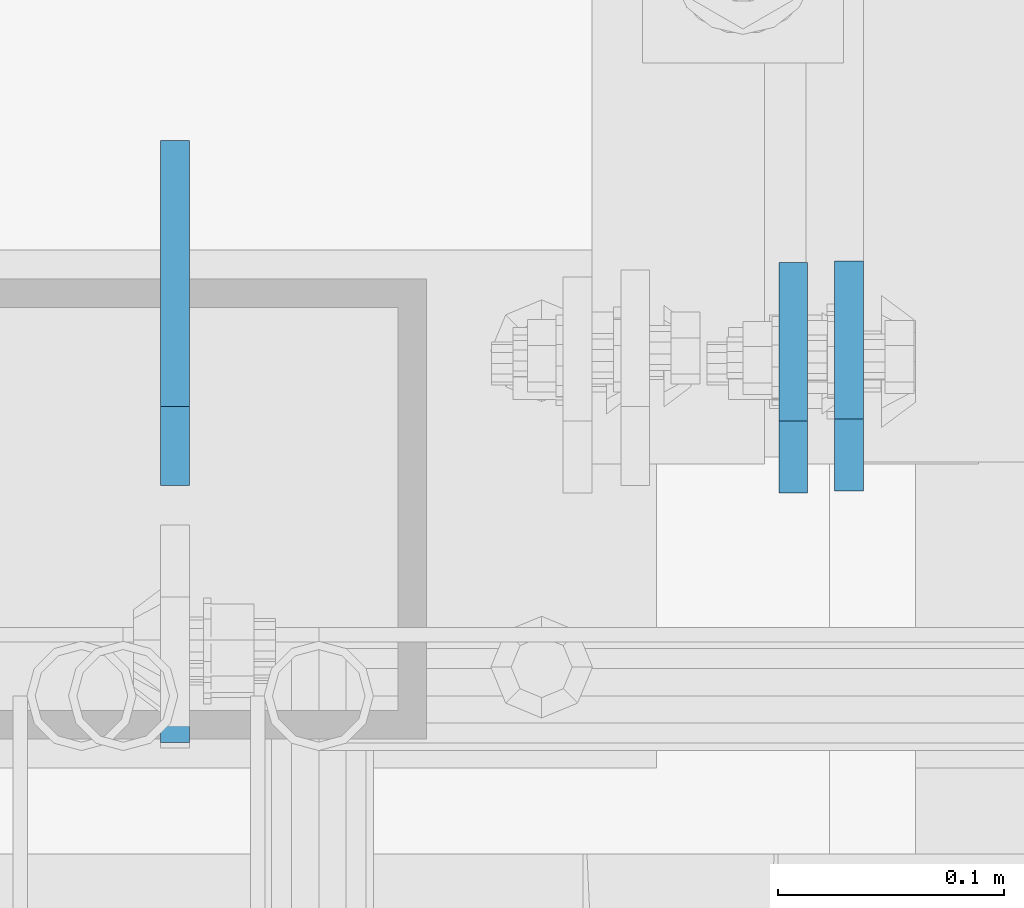
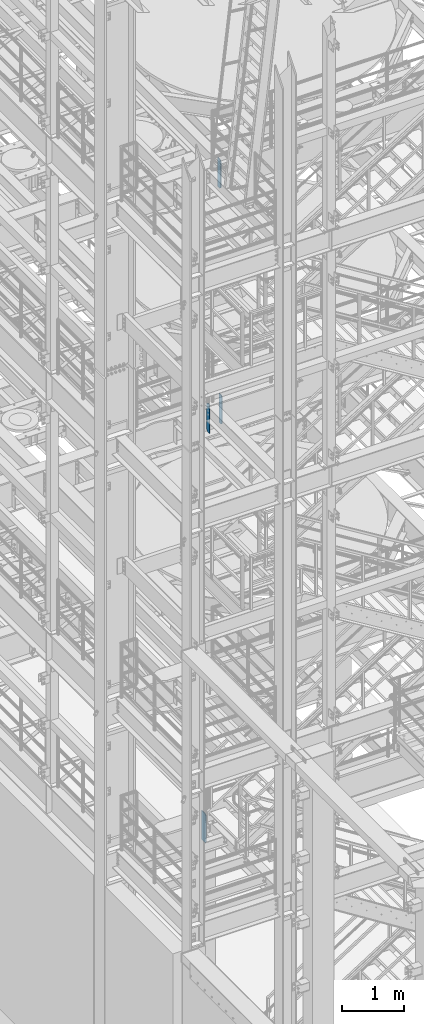
# One storey, part 1470 of 1876: 4 plates, 3 elements without a shape of their own.
"""IFC2X3 building model written with IfcOpenShell, lengths in millimetres."""

from ifc_helpers import new_model, si_unit, frame, origin_with_axes, place, context, subcontext, project, spatial, faceted_brep, material, type_object, element, aggregate, save


model = new_model("IFC2X3")

# Units and contexts
model_context = context("Model", 3, precision=1e-05, world=origin_with_axes())
body_context = subcontext(model_context, "Body", "Model", "MODEL_VIEW")
ifc_project = project(units=[si_unit("LENGTHUNIT", "METRE", prefix="MILLI"), si_unit("AREAUNIT", "SQUARE_METRE"), si_unit("VOLUMEUNIT", "CUBIC_METRE"), si_unit("MASSUNIT", "GRAM", prefix="KILO"), si_unit("TIMEUNIT", "SECOND"), si_unit("PLANEANGLEUNIT", "RADIAN"), si_unit("SOLIDANGLEUNIT", "STERADIAN"), si_unit("THERMODYNAMICTEMPERATUREUNIT", "DEGREE_CELSIUS"), si_unit("LUMINOUSINTENSITYUNIT", "LUMEN")], contexts=[model_context])

# Site, building, storey
site_placement = place(None, origin_with_axes())
site = spatial("IfcSite", under=ifc_project, at=site_placement, CompositionType="ELEMENT")
building_placement = place(site_placement, origin_with_axes())
building = spatial("IfcBuilding", under=site, at=building_placement, Name="Undefined", CompositionType="ELEMENT")
storey_placement = place(building_placement, origin_with_axes())
storey = spatial("IfcBuildingStorey", under=building, at=storey_placement, Name="Undefined", CompositionType="ELEMENT", Elevation=0.0)

# Assembly, plates
assembly_1_placement = place(storey_placement, origin_with_axes())
assembly_1 = element("IfcElementAssembly", 1, at=assembly_1_placement, inside=storey, Name="BEAM", AssemblyPlace="NOTDEFINED", PredefinedType="RIGID_FRAME")
ifc_material = material(Name="STEEL/A36")
plate_type_1 = type_object("IfcPlateType", PredefinedType="NOTDEFINED")
plate_1_placement = place(assembly_1_placement, frame((1717.67499990463, -4579.9375, 12709.525), z_axis=(0.0, 0.0, 1.0), x_axis=(0.0, -1.0, 0.0)))
plate_1 = element("IfcPlate", 2, at=plate_1_placement, type_object=plate_type_1, material=ifc_material, Name="PLATE", context=body_context, shape_type="Brep", body=[
    faceted_brep([(0.0, -6.34999999999991, 34.9249992370605), (0.0, -6.35000000000036, 538.162475585938), (0.0, 6.35000000000036, 538.162475585938), (0.0, 6.34999999999991, 34.9249992370605), (34.9249992370605, -6.34999999999991, 573.087524414062), (34.9249992370605, 6.34999999999991, 573.087524414062), (95.25, -6.34999999999991, 573.087524414062), (95.25, 6.34999999999991, 573.087524414062), (95.25, -6.35000000000036, 0.0), (95.25, 6.35000000000036, 0.0), (34.9249992370605, -6.34999999999991, 0.0), (34.9249992370605, 6.34999999999991, 0.0)], [[[0, 1, 2, 3]], [[1, 4, 5, 2]], [[4, 6, 7, 5]], [[6, 8, 9, 7]], [[8, 10, 11, 9]], [[10, 0, 3, 11]], [[5, 7, 9, 11, 3, 2]], [[10, 8, 6, 4, 1, 0]]]),
])
plate_type_2 = type_object("IfcPlateType", PredefinedType="NOTDEFINED")
plate_2_placement = place(assembly_1_placement, frame((2015.33153078443, -4564.0625, 12709.525), z_axis=(0.0, 0.0, 1.0), x_axis=(0.0, 1.0, 0.0)))
plate_2 = element("IfcPlate", 3, at=plate_2_placement, type_object=plate_type_2, material=ifc_material, Name="PLATE", context=body_context, shape_type="Brep", body=[
    faceted_brep([(0.0, -6.34999999999991, 31.75), (0.0, -6.35000000000036, 541.337524414062), (0.0, 6.35000000000036, 541.337524414062), (0.0, 6.34999999999991, 31.75), (31.75, -6.35000000000036, 573.087524414062), (31.75, 6.35000000000036, 573.087524414062), (101.599998474121, -6.35000000000036, 573.087524414062), (101.599998474121, 6.35000000000036, 573.087524414062), (101.599998474121, -6.35000000000036, 0.0), (101.599998474121, 6.35000000000036, 0.0), (31.75, -6.34999999999991, 0.0), (31.75, 6.34999999999991, 0.0)], [[[0, 1, 2, 3]], [[1, 4, 5, 2]], [[4, 6, 7, 5]], [[6, 8, 9, 7]], [[8, 10, 11, 9]], [[10, 0, 3, 11]], [[5, 7, 9, 11, 3, 2]], [[10, 8, 6, 4, 1, 0]]]),
])
aggregate(assembly_1, [plate_2, plate_1])

# Assembly, plate
assembly_2_placement = place(storey_placement, origin_with_axes())
assembly_2 = element("IfcElementAssembly", 4, at=assembly_2_placement, inside=storey, Name="BEAM", AssemblyPlace="NOTDEFINED", PredefinedType="RIGID_FRAME")
plate_3_placement = place(assembly_2_placement, frame((1990.72488635592, -4564.85625, 17387.8875), z_axis=(0.0, 0.0, 1.0), x_axis=(0.0, 1.0, 0.0)))
plate_3 = element("IfcPlate", 5, at=plate_3_placement, type_object=plate_type_2, material=ifc_material, Name="PLATE", context=body_context, shape_type="Brep", body=[
    faceted_brep([(0.0, -6.34999999999991, 31.75), (0.0, -6.35000000000036, 538.162475585938), (0.0, 6.35000000000036, 538.162475585938), (0.0, 6.34999999999991, 31.75), (31.75, -6.35000000000036, 569.912475585938), (31.75, 6.35000000000036, 569.912475585938), (101.599998474121, -6.34999999999991, 569.912475585938), (101.599998474121, 6.34999999999991, 569.912475585938), (101.599998474121, -6.35000000000036, 0.0), (101.599998474121, 6.35000000000036, 0.0), (31.75, -6.34999999999991, 0.0), (31.75, 6.34999999999991, 0.0)], [[[0, 1, 2, 3]], [[1, 4, 5, 2]], [[4, 6, 7, 5]], [[6, 8, 9, 7]], [[8, 10, 11, 9]], [[10, 0, 3, 11]], [[5, 7, 9, 11, 3, 2]], [[10, 8, 6, 4, 1, 0]]]),
])
aggregate(assembly_2, [plate_3])

assembly_3_placement = place(storey_placement, origin_with_axes())
assembly_3 = element("IfcElementAssembly", 6, at=assembly_3_placement, inside=storey, Name="BEAM", AssemblyPlace="NOTDEFINED", PredefinedType="RIGID_FRAME")
plate_type_3 = type_object("IfcPlateType", PredefinedType="NOTDEFINED")
plate_4_placement = place(assembly_3_placement, frame((1717.67499990463, -4561.68125, 4519.6125), z_axis=(0.0, 0.0, 1.0), x_axis=(0.0, 1.0, 0.0)))
plate_4 = element("IfcPlate", 7, at=plate_4_placement, type_object=plate_type_3, material=ifc_material, Name="PLATE", context=body_context, shape_type="Brep", body=[
    faceted_brep([(0.0, -6.34999999999991, 34.9249992370605), (0.0, -6.34999999999991, 539.75), (0.0, 6.34999999999991, 539.75), (0.0, 6.34999999999991, 34.9249992370605), (34.9249992370605, -6.34999999999991, 574.674987792969), (34.9249992370605, 6.34999999999991, 574.674987792969), (152.399993896484, -6.34999999999991, 574.674987792969), (152.399993896484, 6.34999999999991, 574.674987792969), (152.399993896478, -6.3499999999849, 0.0), (152.399993896482, 6.35000000000991, 0.0), (34.9249992370605, -6.34999999999991, 0.0), (34.9249992370605, 6.34999999999991, 0.0)], [[[0, 1, 2, 3]], [[1, 4, 5, 2]], [[4, 6, 7, 5]], [[6, 8, 9, 7]], [[8, 10, 11, 9]], [[10, 0, 3, 11]], [[5, 7, 9, 11, 3, 2]], [[10, 8, 6, 4, 1, 0]]]),
])
aggregate(assembly_3, [plate_4])

save(model, "model.ifc")
